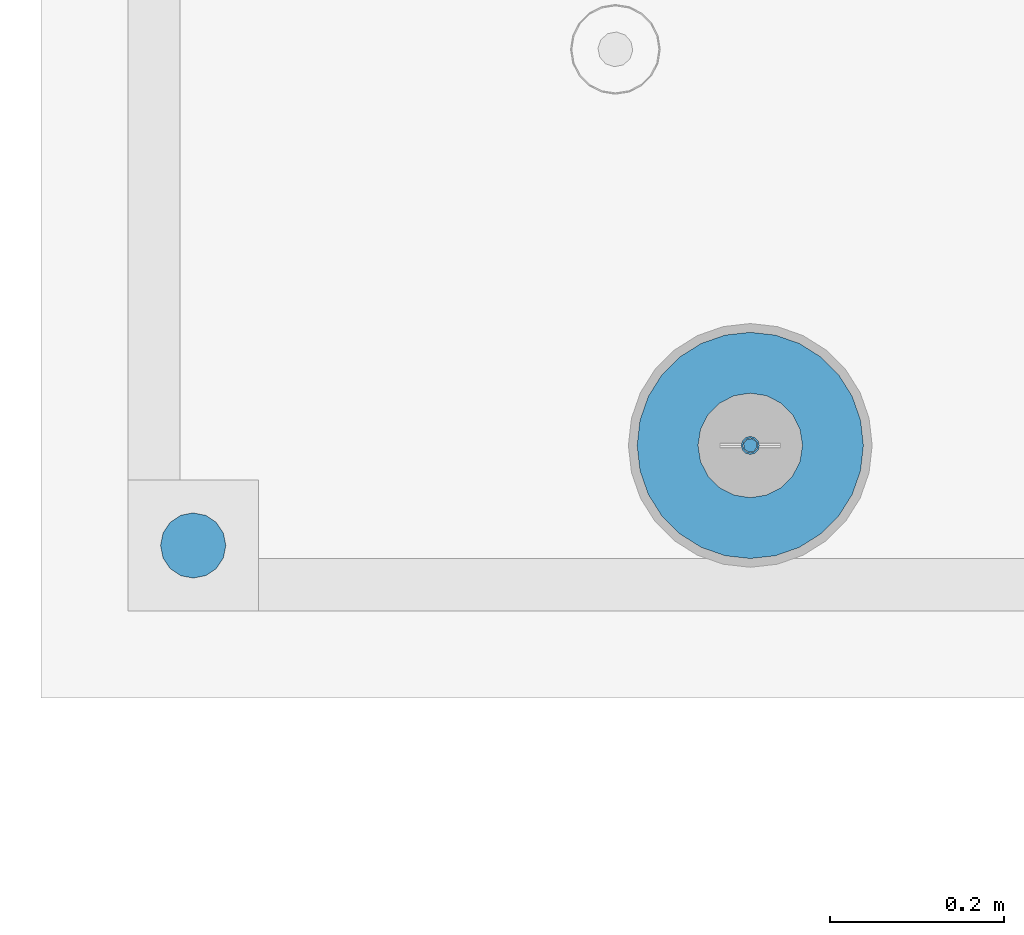
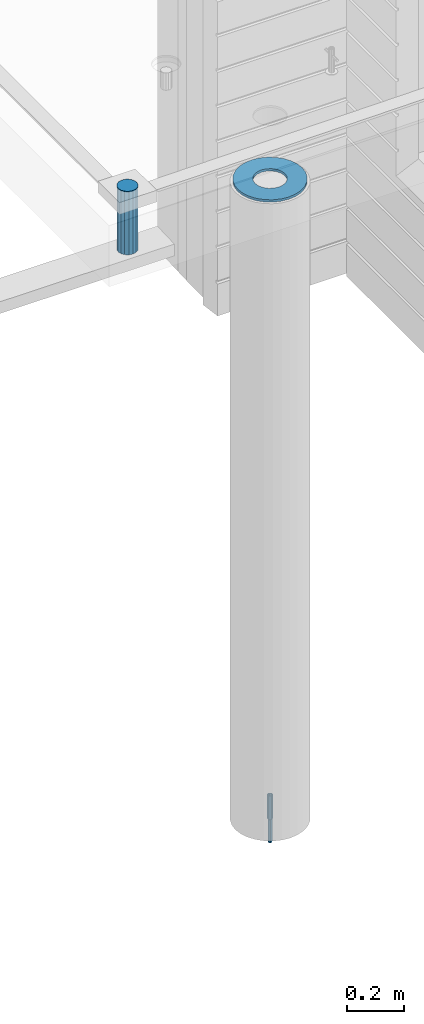
# One storey, part 8 of 349: 4 columns, 4 elements without a shape of their own.
"""IFC2X3 building model written with IfcOpenShell, lengths in millimetres."""

from ifc_helpers import new_model, si_unit, frame, origin_with_axes, place, context, subcontext, project, spatial, faceted_brep, material, type_object, element, aggregate, save


model = new_model("IFC2X3")

# Units and contexts
model_context = context("Model", 3, precision=1e-05, world=origin_with_axes())
body_context = subcontext(model_context, "Body", "Model", "MODEL_VIEW")
ifc_project = project(units=[si_unit("LENGTHUNIT", "METRE", prefix="MILLI"), si_unit("AREAUNIT", "SQUARE_METRE"), si_unit("VOLUMEUNIT", "CUBIC_METRE"), si_unit("MASSUNIT", "GRAM", prefix="KILO"), si_unit("TIMEUNIT", "SECOND"), si_unit("PLANEANGLEUNIT", "RADIAN"), si_unit("SOLIDANGLEUNIT", "STERADIAN"), si_unit("THERMODYNAMICTEMPERATUREUNIT", "DEGREE_CELSIUS"), si_unit("LUMINOUSINTENSITYUNIT", "LUMEN")], contexts=[model_context])

# Site, building, storey
site_placement = place(None, origin_with_axes())
site = spatial("IfcSite", under=ifc_project, at=site_placement, CompositionType="ELEMENT")
building_placement = place(site_placement, origin_with_axes())
building = spatial("IfcBuilding", under=site, at=building_placement, CompositionType="ELEMENT")
storey_placement = place(building_placement, origin_with_axes())
storey = spatial("IfcBuildingStorey", under=building, at=storey_placement, Name="4", CompositionType="ELEMENT", Elevation=0.0)

# Assembly, column
assembly_1_placement = place(storey_placement, origin_with_axes())
assembly_1 = element("IfcElementAssembly", 1, at=assembly_1_placement, inside=storey, AssemblyPlace="NOTDEFINED", PredefinedType="REINFORCEMENT_UNIT")
ifc_material_1 = material()
column_type_1 = type_object("IfcColumnType", Name="D75", PredefinedType="NOTDEFINED")
column_1_placement = place(assembly_1_placement, frame((7209.98489066622, 7834.99985681325, 93440.0), z_axis=(-0.000100006999999935, 0.9999999949993, 0.0), x_axis=(0.0, 0.0, 1.0)))
column_1 = element("IfcColumn", 2, at=column_1_placement, type_object=column_type_1, material=ifc_material_1, ObjectType="D75", context=body_context, shape_type="Brep", body=[
    faceted_brep([(0.0, -37.4999999999991, 1.81898940354586e-12), (0.0, -34.6454824691718, -14.3506287136888), (270.0, -34.6454824691718, -14.3506287136888), (270.0, -37.4999999999991, 1.81898940354586e-12), (0.0, -26.5165042944936, -26.5165042944936), (270.0, -26.5165042944936, -26.5165042944936), (0.0, -14.3506287136906, -34.6454824691718), (270.0, -14.3506287136906, -34.6454824691718), (0.0, 9.09494701772928e-13, -37.4999999999982), (270.0, 9.09494701772928e-13, -37.4999999999982), (0.0, 14.3506287136915, -34.6454824691718), (270.0, 14.3506287136915, -34.6454824691718), (0.0, 26.5165042944973, -26.5165042944927), (270.0, 26.5165042944973, -26.5165042944927), (0.0, 34.6454824691746, -14.3506287136897), (270.0, 34.6454824691746, -14.3506287136897), (0.0, 37.5000000000018, 1.81898940354586e-12), (270.0, 37.5000000000018, 1.81898940354586e-12), (0.0, 34.6454824691755, 14.3506287136925), (270.0, 34.6454824691755, 14.3506287136925), (0.0, 26.5165042944964, 26.5165042944973), (270.0, 26.5165042944964, 26.5165042944973), (0.0, 14.3506287136934, 34.6454824691755), (270.0, 14.3506287136934, 34.6454824691755), (0.0, 1.81898940354586e-12, 37.5000000000027), (270.0, 1.81898940354586e-12, 37.5000000000027), (0.0, -14.3506287136897, 34.6454824691746), (270.0, -14.3506287136897, 34.6454824691746), (0.0, -26.5165042944946, 26.5165042944973), (270.0, -26.5165042944946, 26.5165042944973), (0.0, -34.6454824691718, 14.3506287136925), (270.0, -34.6454824691718, 14.3506287136925)], [[[0, 1, 2, 3]], [[1, 4, 5, 2]], [[4, 6, 7, 5]], [[6, 8, 9, 7]], [[8, 10, 11, 9]], [[10, 12, 13, 11]], [[12, 14, 15, 13]], [[14, 16, 17, 15]], [[16, 18, 19, 17]], [[18, 20, 21, 19]], [[20, 22, 23, 21]], [[22, 24, 25, 23]], [[24, 26, 27, 25]], [[26, 28, 29, 27]], [[28, 30, 31, 29]], [[30, 0, 3, 31]], [[5, 7, 9, 11, 13, 15, 17, 19, 21, 23, 25, 27, 29, 31, 3, 2]], [[30, 28, 26, 24, 22, 20, 18, 16, 14, 12, 10, 8, 6, 4, 1, 0]]]),
])
aggregate(assembly_1, [column_1])

# Assemblies, columns
assembly_2_placement = place(storey_placement, origin_with_axes())
assembly_2 = element("IfcElementAssembly", 3, at=assembly_2_placement, inside=storey, AssemblyPlace="NOTDEFINED", PredefinedType="REINFORCEMENT_UNIT")
assembly_3_placement = place(assembly_2_placement, origin_with_axes())
assembly_3 = element("IfcElementAssembly", 4, at=assembly_3_placement, Name="Steel Assembly", AssemblyPlace="NOTDEFINED", PredefinedType="RIGID_FRAME")
ifc_material_2 = material(Name="STEEL/S235JR")
column_type_2 = type_object("IfcColumnType", Name="D16", PredefinedType="NOTDEFINED")
column_2_placement = place(assembly_3_placement, frame((7850.00048014349, 7949.98420120467, 90625.0), z_axis=(-0.261346946111888, -0.96524492941325, 0.0), x_axis=(0.0, 0.0, 1.0)))
column_2 = element("IfcColumn", 5, at=column_2_placement, type_object=column_type_2, material=ifc_material_2, Name="M16", ObjectType="D16", context=body_context, shape_type="Brep", body=[
    faceted_brep([(0.0, -8.0, 0.0), (0.0, -5.65685424949334, -5.65685424949334), (150.0, -5.65685424949697, -5.65685424949334), (150.0, -8.00000000000364, 0.0), (0.0, 0.0, -8.0), (150.0, -7.27595761418343e-12, -7.99999999999636), (0.0, 5.65685424949334, -5.65685424949334), (150.0, 5.6568542494897, -5.65685424949334), (0.0, 8.0, 0.0), (150.0, 8.0, -3.63797880709171e-12), (0.0, 5.65685424949334, 5.65685424949334), (150.0, 5.65685424949334, 5.65685424949697), (0.0, 0.0, 8.0), (150.0, -3.63797880709171e-12, 8.0), (0.0, -5.65685424949334, 5.65685424949334), (150.0, -5.65685424949334, 5.6568542494897)], [[[0, 1, 2, 3]], [[1, 4, 5, 2]], [[4, 6, 7, 5]], [[6, 8, 9, 7]], [[8, 10, 11, 9]], [[10, 12, 13, 11]], [[12, 14, 15, 13]], [[14, 0, 3, 15]], [[5, 7, 9, 11, 13, 15, 3, 2]], [[14, 12, 10, 8, 6, 4, 1, 0]]]),
])
aggregate(assembly_3, [column_2])
assembly_4_placement = place(assembly_2_placement, origin_with_axes())
assembly_4 = element("IfcElementAssembly", 6, at=assembly_4_placement, Name="Steel Assembly", AssemblyPlace="NOTDEFINED", PredefinedType="RIGID_FRAME")
ifc_material_3 = material(Name="STEEL/Steel_Undefined")
column_type_3 = type_object("IfcColumnType", PredefinedType="NOTDEFINED")
column_3_placement = place(assembly_4_placement, frame((7849.99879520436, 7949.98488883804, 90725.0), z_axis=(0.0, 1.0, 0.0), x_axis=(0.0, 0.0, 1.0)))
column_3 = element("IfcColumn", 7, at=column_3_placement, type_object=column_type_3, material=ifc_material_3, context=body_context, shape_type="Brep", body=[
    faceted_brep([(0.0, -8.49999999999272, -1.45519152283669e-11), (0.0, -7.36121593215648, 4.24999999998545), (100.000000000262, -7.36121593215648, 4.24999999998545), (100.000000000262, -8.49999999999272, -1.45519152283669e-11), (0.0, -4.24999999998545, 7.36121593216376), (100.000000000262, -4.24999999998545, 7.36121593216376), (0.0, 1.45519152283669e-11, 8.49999999998545), (100.000000000262, 1.45519152283669e-11, 8.49999999998545), (0.0, 4.25000000001455, 7.36121593216376), (100.000000000262, 4.25000000001455, 7.36121593216376), (0.0, 7.36121593217104, 4.24999999998545), (100.000000000262, 7.36121593217104, 4.24999999998545), (0.0, 8.50000000000728, 0.0), (100.000000000262, 8.50000000000728, 0.0), (0.0, 7.36121593217104, -4.25000000001455), (100.000000000262, 7.36121593217104, -4.25000000001455), (0.0, 4.25000000000728, -7.36121593219286), (100.000000000262, 4.25000000000728, -7.36121593219286), (0.0, 7.27595761418343e-12, -8.5), (100.000000000262, 7.27595761418343e-12, -8.5), (0.0, -4.24999999999272, -7.36121593217831), (100.000000000262, -4.24999999999272, -7.36121593217831), (0.0, -7.36121593215648, -4.25), (100.000000000262, -7.36121593215648, -4.25), (0.0, -10.4999999999927, -1.45519152283669e-11), (0.0, -9.09326673972828, -5.25000000001455), (100.000000000262, -9.09326673972828, -5.25000000001455), (100.000000000262, -10.4999999999927, -1.45519152283669e-11), (0.0, -5.24999999998545, -9.09326673974283), (100.000000000262, -5.24999999998545, -9.09326673974283), (0.0, 7.27595761418343e-12, -10.5), (100.000000000262, 7.27595761418343e-12, -10.5), (0.0, 5.25000000001455, -9.09326673975738), (100.000000000262, 5.25000000001455, -9.09326673975738), (0.0, 9.09326673975011, -5.25000000001455), (100.000000000262, 9.09326673975011, -5.25000000001455), (0.0, 10.5000000000073, -1.45519152283669e-11), (100.000000000262, 10.5000000000073, -1.45519152283669e-11), (0.0, 9.09326673975011, 5.25), (100.000000000262, 9.09326673975011, 5.25), (0.0, 5.25000000000728, 9.09326673972828), (100.000000000262, 5.25000000000728, 9.09326673972828), (0.0, 1.45519152283669e-11, 10.4999999999854), (100.000000000262, 1.45519152283669e-11, 10.4999999999854), (0.0, -5.24999999999272, 9.09326673972828), (100.000000000262, -5.24999999999272, 9.09326673972828), (0.0, -9.09326673972828, 5.24999999998545), (100.000000000262, -9.09326673972828, 5.24999999998545)], [[[0, 1, 2, 3]], [[1, 4, 5, 2]], [[4, 6, 7, 5]], [[6, 8, 9, 7]], [[8, 10, 11, 9]], [[10, 12, 13, 11]], [[12, 14, 15, 13]], [[14, 16, 17, 15]], [[16, 18, 19, 17]], [[18, 20, 21, 19]], [[20, 22, 23, 21]], [[22, 0, 3, 23]], [[24, 25, 26, 27]], [[25, 28, 29, 26]], [[28, 30, 31, 29]], [[30, 32, 33, 31]], [[32, 34, 35, 33]], [[34, 36, 37, 35]], [[36, 38, 39, 37]], [[38, 40, 41, 39]], [[40, 42, 43, 41]], [[42, 44, 45, 43]], [[44, 46, 47, 45]], [[46, 24, 27, 47]], [[29, 31, 33, 35, 37, 39, 41, 43, 45, 47, 27, 26], [5, 7, 9, 11, 13, 15, 17, 19, 21, 23, 3, 2]], [[46, 44, 42, 40, 38, 36, 34, 32, 30, 28, 25, 24], [22, 20, 18, 16, 14, 12, 10, 8, 6, 4, 1, 0]]]),
])
aggregate(assembly_4, [column_3])
ifc_material_4 = material()
column_type_4 = type_object("IfcColumnType", Name="D260", PredefinedType="NOTDEFINED")
column_4_placement = place(assembly_2_placement, frame((7849.99879520436, 7949.98488883804, 93435.0), z_axis=(-1.0, 3.00000001838171e-08, 0.0), x_axis=(0.0, 0.0, 1.0)))
column_4 = element("IfcColumn", 8, at=column_4_placement, type_object=column_type_4, material=ifc_material_4, Name="60", ObjectType="D260", context=body_context, shape_type="Brep", body=[
    faceted_brep([(10.0, -18.541019662498, -57.0633909777098), (0.0, -18.541019662498, -57.0633909777098), (0.0, -35.2671151375471, -48.5410196624944), (10.0, -35.2671151375471, -48.5410196624944), (0.0, -48.541019662498, -35.2671151375471), (10.0, -48.541019662498, -35.2671151375471), (0.0, -57.0633909777098, -18.5410196624944), (10.0, -57.0633909777098, -18.5410196624944), (0.0, -60.0, 0.0), (10.0, -60.0, 0.0), (0.0, -57.0633909777098, 18.5410196624944), (10.0, -57.0633909777098, 18.5410196624944), (0.0, -48.541019662498, 35.2671151375471), (10.0, -48.541019662498, 35.2671151375471), (0.0, -35.2671151375471, 48.5410196624944), (10.0, -35.2671151375471, 48.5410196624944), (0.0, -18.541019662498, 57.0633909777098), (10.0, -18.541019662498, 57.0633909777098), (0.0, 0.0, 60.0), (10.0, 0.0, 60.0), (0.0, 18.541019662498, 57.0633909777098), (10.0, 18.541019662498, 57.0633909777098), (0.0, 35.2671151375471, 48.5410196624944), (10.0, 35.2671151375471, 48.5410196624944), (0.0, 48.541019662498, 35.2671151375471), (10.0, 48.541019662498, 35.2671151375471), (0.0, 57.0633909777098, 18.5410196624944), (10.0, 57.0633909777098, 18.5410196624944), (0.0, 60.0, 0.0), (10.0, 60.0, 0.0), (0.0, 57.0633909777098, -18.5410196624944), (10.0, 57.0633909777098, -18.5410196624944), (0.0, 48.541019662498, -35.2671151375471), (10.0, 48.541019662498, -35.2671151375471), (0.0, 35.2671151375471, -48.5410196624944), (10.0, 35.2671151375471, -48.5410196624944), (0.0, 18.541019662498, -57.0633909777098), (10.0, 18.541019662498, -57.0633909777098), (0.0, 0.0, -60.0), (10.0, 0.0, -60.0), (0.0, -126.740628583637, -28.9277214143222), (0.0, -117.125952827315, -56.4048860852854), (10.0, -117.125952827315, -56.4048860852854), (10.0, -126.740628583637, -28.9277214143222), (0.0, -101.638092720845, -81.0536742416371), (10.0, -101.638092720845, -81.0536742416371), (0.0, -81.0536742416371, -101.638092720845), (10.0, -81.0536742416371, -101.638092720845), (0.0, -56.4048860852818, -117.125952827315), (10.0, -56.4048860852818, -117.125952827315), (0.0, -28.9277214143222, -126.740628583641), (10.0, -28.9277214143222, -126.740628583641), (0.0, 0.0, -130.0), (10.0, 0.0, -130.0), (0.0, 28.9277214143222, -126.740628583641), (10.0, 28.9277214143222, -126.740628583641), (0.0, 56.4048860852818, -117.125952827315), (10.0, 56.4048860852818, -117.125952827315), (0.0, 81.0536742416371, -101.638092720845), (10.0, 81.0536742416371, -101.638092720845), (0.0, 101.638092720845, -81.0536742416371), (10.0, 101.638092720845, -81.0536742416371), (0.0, 117.125952827315, -56.4048860852854), (10.0, 117.125952827315, -56.4048860852854), (0.0, 126.740628583637, -28.9277214143222), (10.0, 126.740628583637, -28.9277214143222), (0.0, 130.0, -1.81898940354586e-12), (10.0, 130.0, 0.0), (0.0, 126.740628583637, 28.9277214143222), (10.0, 126.740628583637, 28.9277214143222), (0.0, 117.125952827315, 56.4048860852854), (10.0, 117.125952827315, 56.4048860852854), (0.0, 101.638092720845, 81.0536742416371), (10.0, 101.638092720845, 81.0536742416371), (0.0, 81.0536742416371, 101.638092720845), (10.0, 81.0536742416371, 101.638092720845), (0.0, 56.4048860852818, 117.125952827315), (10.0, 56.4048860852818, 117.125952827315), (0.0, 28.9277214143222, 126.740628583641), (10.0, 28.9277214143222, 126.740628583641), (0.0, 0.0, 130.0), (10.0, 0.0, 130.0), (0.0, -28.9277214143222, 126.740628583641), (10.0, -28.9277214143222, 126.740628583641), (0.0, -56.4048860852818, 117.125952827315), (10.0, -56.4048860852818, 117.125952827315), (0.0, -81.0536742416371, 101.638092720845), (10.0, -81.0536742416371, 101.638092720845), (0.0, -101.638092720845, 81.0536742416371), (10.0, -101.638092720845, 81.0536742416371), (0.0, -117.125952827315, 56.4048860852854), (10.0, -117.125952827315, 56.4048860852854), (0.0, -126.740628583637, 28.9277214143222), (10.0, -126.740628583637, 28.9277214143222), (0.0, -130.0, -3.63797880709171e-12), (10.0, -130.0, 0.0)], [[[0, 1, 2, 3]], [[3, 2, 4, 5]], [[5, 4, 6, 7]], [[7, 6, 8, 9]], [[9, 8, 10, 11]], [[11, 10, 12, 13]], [[13, 12, 14, 15]], [[15, 14, 16, 17]], [[17, 16, 18, 19]], [[19, 18, 20, 21]], [[21, 20, 22, 23]], [[23, 22, 24, 25]], [[25, 24, 26, 27]], [[27, 26, 28, 29]], [[29, 28, 30, 31]], [[31, 30, 32, 33]], [[33, 32, 34, 35]], [[35, 34, 36, 37]], [[37, 36, 38, 39]], [[39, 38, 1, 0]], [[40, 41, 42, 43]], [[41, 44, 45, 42]], [[44, 46, 47, 45]], [[46, 48, 49, 47]], [[48, 50, 51, 49]], [[50, 52, 53, 51]], [[52, 54, 55, 53]], [[54, 56, 57, 55]], [[56, 58, 59, 57]], [[58, 60, 61, 59]], [[60, 62, 63, 61]], [[62, 64, 65, 63]], [[64, 66, 67, 65]], [[66, 68, 69, 67]], [[68, 70, 71, 69]], [[70, 72, 73, 71]], [[72, 74, 75, 73]], [[74, 76, 77, 75]], [[76, 78, 79, 77]], [[78, 80, 81, 79]], [[80, 82, 83, 81]], [[82, 84, 85, 83]], [[84, 86, 87, 85]], [[86, 88, 89, 87]], [[88, 90, 91, 89]], [[90, 92, 93, 91]], [[92, 94, 95, 93]], [[42, 45, 47, 49, 51, 53, 55, 57, 59, 61, 63, 65, 67, 69, 71, 73, 75, 77, 79, 81, 83, 85, 87, 89, 91, 93, 95, 43], [3, 5, 7, 9, 11, 13, 15, 17, 19, 21, 23, 25, 27, 29, 31, 33, 35, 37, 39, 0]], [[94, 40, 43, 95]], [[92, 90, 88, 86, 84, 82, 80, 78, 76, 74, 72, 70, 68, 66, 64, 62, 60, 58, 56, 54, 52, 50, 48, 46, 44, 41, 40, 94], [34, 32, 30, 28, 26, 24, 22, 20, 18, 16, 14, 12, 10, 8, 6, 4, 2, 1, 38, 36]]]),
])
aggregate(assembly_2, [assembly_4, assembly_3, column_4])

save(model, "model.ifc")
